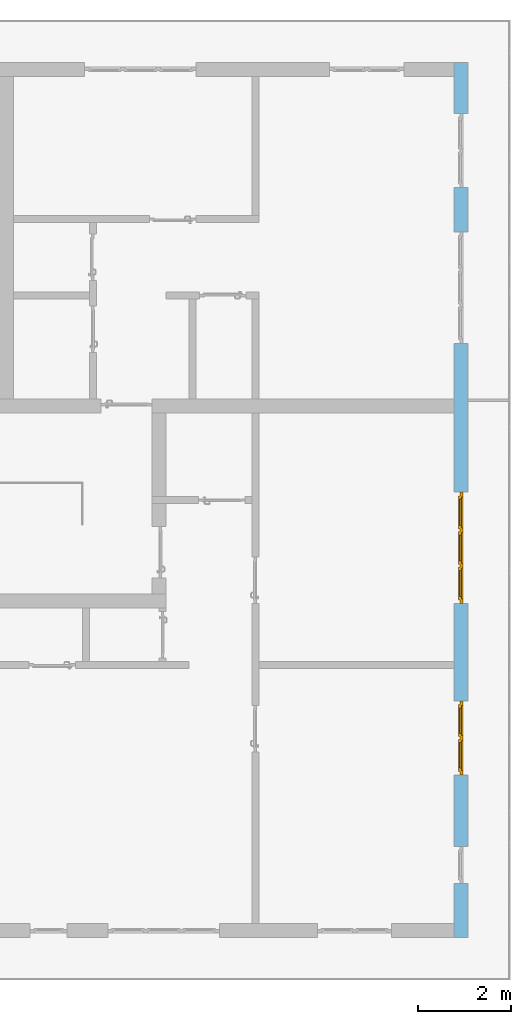
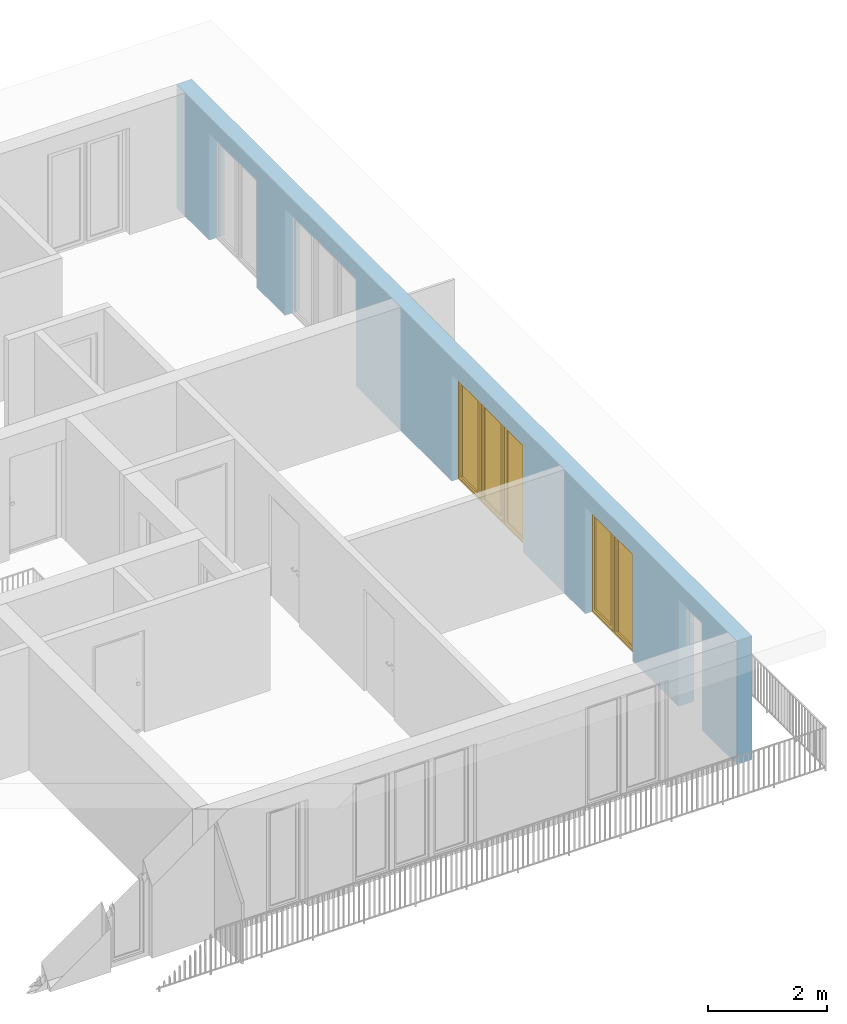
# One storey, part 22 of 54: 2 windows, 5 openings, plus 1 element that does not belong to this part.
"""IFC4 building model written with IfcOpenShell, lengths in metres."""

from ifc_helpers import new_model, entity, si_unit, converted_unit, derived_unit, direction, frame, origin_with_axes, place, context, subcontext, project, spatial, polygons, source, transform, mapped, material, type_object, element, fill, save


model = new_model("IFC4")

# Units and contexts
model_context = context("Model", 3, precision=1e-05, world=origin_with_axes(), true_north=direction((0.0, 1.0)))
body_context = subcontext(model_context, "Body", "Model", "MODEL_VIEW")
ifc_project = project(units=[si_unit("LENGTHUNIT", "METRE"), si_unit("AREAUNIT", "SQUARE_METRE"), si_unit("VOLUMEUNIT", "CUBIC_METRE"), converted_unit("PLANEANGLEUNIT", "DEGREE", entity("IfcPlaneAngleMeasure", 0.0174532925199), si_unit("PLANEANGLEUNIT", "RADIAN"), dimensions=[0, 0, 0, 0, 0, 0, 0]), converted_unit("TIMEUNIT", "Year", entity("IfcTimeMeasure", 31556926.0), si_unit("TIMEUNIT", "SECOND"), dimensions=[0, 0, 1, 0, 0, 0, 0]), si_unit("MASSUNIT", "GRAM", prefix="KILO"), si_unit("THERMODYNAMICTEMPERATUREUNIT", "DEGREE_CELSIUS"), si_unit("LUMINOUSINTENSITYUNIT", "LUMEN"), si_unit("ENERGYUNIT", "JOULE", prefix="MEGA"), derived_unit("THERMALCONDUCTANCEUNIT", [(si_unit("POWERUNIT", "WATT"), 1), (si_unit("LENGTHUNIT", "METRE"), -1), (si_unit("THERMODYNAMICTEMPERATUREUNIT", "KELVIN"), -1)]), derived_unit("SPECIFICHEATCAPACITYUNIT", [(si_unit("ENERGYUNIT", "JOULE"), 1), (si_unit("MASSUNIT", "GRAM", prefix="KILO"), -1), (si_unit("THERMODYNAMICTEMPERATUREUNIT", "KELVIN"), -1)]), derived_unit("MASSDENSITYUNIT", [(si_unit("MASSUNIT", "GRAM", prefix="KILO"), 1), (si_unit("VOLUMEUNIT", "CUBIC_METRE"), -1)])], contexts=[model_context])

# Site, building, storey
site_placement = place(None, origin_with_axes())
site = spatial("IfcSite", under=ifc_project, at=site_placement, CompositionType="ELEMENT")
building_placement = place(site_placement, origin_with_axes())
building = spatial("IfcBuilding", under=site, at=building_placement, CompositionType="ELEMENT")
storey_placement = place(building_placement, frame((0.0, 0.0, 9.18), z_axis=(0.0, 0.0, 1.0), x_axis=(1.0, 0.0, 0.0)))
storey = spatial("IfcBuildingStorey", under=building, at=storey_placement, Name="3. Geschoss", CompositionType="ELEMENT", Elevation=9.18)

# Wall, openings, windows
ifc_material = material()
wall_type = type_object("IfcWallType", Name="300", PredefinedType="NOTDEFINED")
wall_placement = place(storey_placement, frame((9.3378006196, -9.92881223104, 0.0), z_axis=(0.0, 0.0, 1.0), x_axis=(0.0, 1.0, 0.0)))
wall = element("IfcWall", 1, at=wall_placement, inside=storey, type_object=wall_type, material=ifc_material, Name="Wand-001", PredefinedType="NOTDEFINED", context=body_context, shape_type="Tessellation", body=[
    polygons([(1.16441876325, 0.1, 2.2), (1.96441876325, 0.1, 2.2), (1.96441876325, 0.0, 2.2), (1.16441876325, 0.0, 2.2), (1.16441876325, 0.3, 2.2), (1.96441876325, 0.3, 2.2), (1.96441876325, 0.1, 0.0), (1.96441876325, 0.0, 0.0), (18.85, 0.0, 2.54), (0.0, 0.0, 2.54), (0.0, 0.0, 0.0), (1.16441876325, 0.0, 0.0), (3.5, 0.0, 0.0), (3.5, 0.0, 2.2), (5.1, 0.0, 2.2), (5.1, 0.0, 0.0), (7.1921181063, 0.0, 0.0), (7.1921181063, 0.0, 2.2), (9.5921181063, 0.0, 2.2), (9.5921181063, 0.0, 0.0), (12.8, 0.0, 0.0), (12.8, 0.0, 2.2), (15.2, 0.0, 2.2), (15.2, 0.0, 0.0), (16.15, 0.0, 0.0), (16.15, 0.0, 2.2), (17.75, 0.0, 2.2), (17.75, 0.0, 0.0), (18.85, 0.0, 0.0), (1.16441876325, 0.1, 0.0), (1.16441876325, 0.3, 0.0), (0.0, 0.3, 0.0), (0.0, 0.3, 2.54), (18.85, 0.3, 2.54), (18.85, 0.3, 0.0), (17.75, 0.3, 0.0), (17.75, 0.3, 2.2), (16.15, 0.3, 2.2), (16.15, 0.3, 0.0), (15.2, 0.3, 0.0), (15.2, 0.3, 2.2), (12.8, 0.3, 2.2), (12.8, 0.3, 0.0), (9.5921181063, 0.3, 0.0), (9.5921181063, 0.3, 2.2), (7.1921181063, 0.3, 2.2), (7.1921181063, 0.3, 0.0), (5.1, 0.3, 0.0), (5.1, 0.3, 2.2), (3.5, 0.3, 2.2), (3.5, 0.3, 0.0), (1.96441876325, 0.3, 0.0), (3.5, 0.1, 0.0), (3.5, 0.1, 2.2), (5.1, 0.1, 2.2), (5.1, 0.1, 0.0), (7.1921181063, 0.1, 0.0), (7.1921181063, 0.1, 2.2), (9.5921181063, 0.1, 2.2), (9.5921181063, 0.1, 0.0), (12.8, 0.1, 0.0), (12.8, 0.1, 2.2), (15.2, 0.1, 2.2), (15.2, 0.1, 0.0), (16.15, 0.1, 0.0), (16.15, 0.1, 2.2), (17.75, 0.1, 2.2), (17.75, 0.1, 0.0)], [[[1, 2, 3, 4]], [[2, 1, 5, 6]], [[2, 7, 8, 3]], [[9, 10, 11, 12, 4, 3, 8, 13, 14, 15, 16, 17, 18, 19, 20, 21, 22, 23, 24, 25, 26, 27, 28, 29]], [[30, 1, 4, 12]], [[1, 30, 31, 5]], [[5, 31, 32, 33, 34, 35, 36, 37, 38, 39, 40, 41, 42, 43, 44, 45, 46, 47, 48, 49, 50, 51, 52, 6]], [[7, 2, 6, 52]], [[7, 52, 51, 53, 13, 8]], [[9, 34, 33, 10]], [[33, 32, 11, 10]], [[31, 30, 12, 11, 32]], [[14, 13, 53, 54]], [[15, 14, 54, 55]], [[16, 15, 55, 56]], [[56, 48, 47, 57, 17, 16]], [[57, 58, 18, 17]], [[58, 59, 19, 18]], [[59, 60, 20, 19]], [[60, 44, 43, 61, 21, 20]], [[22, 21, 61, 62]], [[23, 22, 62, 63]], [[24, 23, 63, 64]], [[64, 40, 39, 65, 25, 24]], [[65, 66, 26, 25]], [[66, 67, 27, 26]], [[67, 68, 28, 27]], [[36, 35, 29, 28, 68]], [[9, 29, 35, 34]], [[68, 67, 37, 36]], [[67, 66, 38, 37]], [[66, 65, 39, 38]], [[41, 40, 64, 63]], [[42, 41, 63, 62]], [[43, 42, 62, 61]], [[60, 59, 45, 44]], [[59, 58, 46, 45]], [[58, 57, 47, 46]], [[49, 48, 56, 55]], [[50, 49, 55, 54]], [[51, 50, 54, 53]]], closed=True),
])
opening_1_placement = place(wall_placement, frame((16.95, 0.0, 0.0), z_axis=(0.0, 0.0, 1.0), x_axis=(1.0, 0.0, 0.0)))
element("IfcOpeningElement", 2, at=opening_1_placement, cuts=wall, Name="Fenster-001", context=body_context, identifier="Reference", shape_type="Tessellation", body=[
    polygons([(0.8, 0.1, 0.0), (0.8, 0.1, 2.2), (0.8, -0.000999999999999, 2.2), (0.8, -0.000999999999999, 0.0), (0.8, 0.301, 0.0), (0.8, 0.301, 2.2), (-0.8, 0.1, 2.2), (-0.8, -0.000999999999999, 2.2), (-0.8, 0.301, 2.2), (-0.8, -0.000999999999999, 0.0), (-0.8, 0.1, 0.0), (-0.8, 0.301, 0.0)], [[[1, 2, 3, 4]], [[2, 1, 5, 6]], [[7, 8, 3, 2, 6, 9]], [[8, 10, 4, 3]], [[1, 4, 10, 11, 12, 5]], [[6, 5, 12, 9]], [[7, 11, 10, 8]], [[11, 7, 9, 12]]], closed=True),
])
opening_2_placement = place(wall_placement, frame((14.0, 0.0, 0.0), z_axis=(0.0, 0.0, 1.0), x_axis=(1.0, 0.0, 0.0)))
element("IfcOpeningElement", 3, at=opening_2_placement, cuts=wall, Name="Fenster-002", context=body_context, identifier="Reference", shape_type="Tessellation", body=[
    polygons([(1.2, 0.1, 0.0), (1.2, 0.1, 2.2), (1.2, -0.000999999999999, 2.2), (1.2, -0.000999999999999, 0.0), (1.2, 0.301, 0.0), (1.2, 0.301, 2.2), (-1.2, 0.1, 2.2), (-1.2, -0.000999999999999, 2.2), (-1.2, 0.301, 2.2), (-1.2, -0.000999999999999, 0.0), (-1.2, 0.1, 0.0), (-1.2, 0.301, 0.0)], [[[1, 2, 3, 4]], [[2, 1, 5, 6]], [[7, 8, 3, 2, 6, 9]], [[8, 10, 4, 3]], [[1, 4, 10, 11, 12, 5]], [[6, 5, 12, 9]], [[7, 11, 10, 8]], [[11, 7, 9, 12]]], closed=True),
])
opening_3_placement = place(wall_placement, frame((8.3921181063, 0.0, 0.0), z_axis=(0.0, 0.0, 1.0), x_axis=(1.0, 0.0, 0.0)))
opening_3 = element("IfcOpeningElement", 4, at=opening_3_placement, cuts=wall, Name="Fenster-002", context=body_context, identifier="Reference", shape_type="Tessellation", body=[
    polygons([(1.2, 0.1, 0.0), (1.2, 0.1, 2.2), (1.2, -0.000999999999999, 2.2), (1.2, -0.000999999999999, 0.0), (1.2, 0.301, 0.0), (1.2, 0.301, 2.2), (-1.2, 0.1, 2.2), (-1.2, -0.000999999999999, 2.2), (-1.2, 0.301, 2.2), (-1.2, -0.000999999999999, 0.0), (-1.2, 0.1, 0.0), (-1.2, 0.301, 0.0)], [[[1, 2, 3, 4]], [[2, 1, 5, 6]], [[7, 8, 3, 2, 6, 9]], [[8, 10, 4, 3]], [[1, 4, 10, 11, 12, 5]], [[6, 5, 12, 9]], [[7, 11, 10, 8]], [[11, 7, 9, 12]]], closed=True),
])
opening_4_placement = place(wall_placement, frame((4.3, 0.0, 0.0), z_axis=(0.0, 0.0, 1.0), x_axis=(1.0, 0.0, 0.0)))
opening_4 = element("IfcOpeningElement", 5, at=opening_4_placement, cuts=wall, Name="Fenster-001", context=body_context, identifier="Reference", shape_type="Tessellation", body=[
    polygons([(0.8, 0.1, 0.0), (0.8, 0.1, 2.2), (0.8, -0.000999999999999, 2.2), (0.8, -0.000999999999999, 0.0), (0.8, 0.301, 0.0), (0.8, 0.301, 2.2), (-0.8, 0.1, 2.2), (-0.8, -0.000999999999999, 2.2), (-0.8, 0.301, 2.2), (-0.8, -0.000999999999999, 0.0), (-0.8, 0.1, 0.0), (-0.8, 0.301, 0.0)], [[[1, 2, 3, 4]], [[2, 1, 5, 6]], [[7, 8, 3, 2, 6, 9]], [[8, 10, 4, 3]], [[1, 4, 10, 11, 12, 5]], [[6, 5, 12, 9]], [[7, 11, 10, 8]], [[11, 7, 9, 12]]], closed=True),
])
opening_5_placement = place(wall_placement, frame((1.56441876325, 0.0, 0.0), z_axis=(0.0, 0.0, 1.0), x_axis=(1.0, 0.0, 0.0)))
element("IfcOpeningElement", 6, at=opening_5_placement, cuts=wall, Name="Fenster-003", context=body_context, identifier="Reference", shape_type="Tessellation", body=[
    polygons([(0.4, 0.1, 0.0), (0.4, 0.1, 2.2), (0.4, -0.000999999999999, 2.2), (0.4, -0.000999999999999, 0.0), (0.4, 0.301, 0.0), (0.4, 0.301, 2.2), (-0.4, 0.1, 2.2), (-0.4, -0.000999999999999, 2.2), (-0.4, 0.301, 2.2), (-0.4, -0.000999999999999, 0.0), (-0.4, 0.1, 0.0), (-0.4, 0.301, 0.0)], [[[1, 2, 3, 4]], [[2, 1, 5, 6]], [[7, 8, 3, 2, 6, 9]], [[8, 10, 4, 3]], [[1, 4, 10, 11, 12, 5]], [[6, 5, 12, 9]], [[7, 11, 10, 8]], [[11, 7, 9, 12]]], closed=True),
])
window_type_1 = type_object("IfcWindowType", Name="3-1+1+1 26", PartitioningType="TRIPLE_PANEL_VERTICAL", PredefinedType="WINDOW")
shared_shape_1 = source(origin_with_axes(), body_context, "Body", "Tessellation", [
    polygons([(-1.2, -0.07, 0.0), (-1.2, 0.0, 0.0), (-1.1, 0.0, 0.1), (-1.1, -0.07, 0.1), (-1.2, -0.07, 2.2), (-1.2, 0.0, 2.2), (-1.1, 0.0, 2.1), (-1.1, -0.07, 2.1)], [[[1, 2, 3, 4]], [[5, 6, 2, 1]], [[2, 6, 7, 3]], [[4, 3, 7, 8]], [[1, 4, 8, 5]], [[8, 7, 6, 5]]], closed=True),
    polygons([(1.2, -0.07, 0.0), (1.2, 0.0, 0.0), (1.2, 0.0, 2.2), (1.2, -0.07, 2.2), (1.1, -0.07, 0.1), (1.1, 0.0, 0.1), (1.1, 0.0, 2.1), (1.1, -0.07, 2.1)], [[[1, 2, 3, 4]], [[5, 6, 2, 1]], [[2, 6, 7, 3]], [[4, 3, 7, 8]], [[1, 4, 8, 5]], [[8, 7, 6, 5]]], closed=True),
    polygons([(-1.2, -0.07, 0.0), (-1.2, 0.0, 0.0), (1.2, 0.0, 0.0), (1.2, -0.07, 0.0), (-1.1, -0.07, 0.1), (-1.1, 0.0, 0.1), (-0.433333333333, 0.0, 0.1), (-0.333333333333, 0.0, 0.1), (0.333333333333, 0.0, 0.1), (0.433333333333, 0.0, 0.1), (1.1, 0.0, 0.1), (1.1, -0.07, 0.1), (0.433333333333, -0.07, 0.1), (0.333333333333, -0.07, 0.1), (-0.333333333333, -0.07, 0.1), (-0.433333333333, -0.07, 0.1)], [[[1, 2, 3, 4]], [[5, 6, 2, 1]], [[2, 6, 7, 8, 9, 10, 11, 3]], [[4, 3, 11, 12]], [[1, 4, 12, 13, 14, 15, 16, 5]], [[16, 7, 6, 5]], [[15, 8, 7, 16]], [[14, 9, 8, 15]], [[13, 10, 9, 14]], [[12, 11, 10, 13]]], closed=True),
    polygons([(-1.2, -0.07, 2.2), (-1.2, 0.0, 2.2), (-1.1, 0.0, 2.1), (-1.1, -0.07, 2.1), (1.2, -0.07, 2.2), (1.2, 0.0, 2.2), (1.1, 0.0, 2.1), (0.433333333333, 0.0, 2.1), (0.333333333333, 0.0, 2.1), (-0.333333333333, 0.0, 2.1), (-0.433333333333, 0.0, 2.1), (-0.433333333333, -0.07, 2.1), (-0.333333333333, -0.07, 2.1), (0.333333333333, -0.07, 2.1), (0.433333333333, -0.07, 2.1), (1.1, -0.07, 2.1)], [[[1, 2, 3, 4]], [[5, 6, 2, 1]], [[2, 6, 7, 8, 9, 10, 11, 3]], [[4, 3, 11, 12]], [[1, 4, 12, 13, 14, 15, 16, 5]], [[16, 7, 6, 5]], [[15, 8, 7, 16]], [[14, 9, 8, 15]], [[13, 10, 9, 14]], [[12, 11, 10, 13]]], closed=True),
    polygons([(0.333333333333, -0.07, 0.1), (0.333333333333, 0.0, 0.1), (0.433333333333, 0.0, 0.1), (0.433333333333, -0.07, 0.1), (0.333333333333, -0.07, 2.1), (0.333333333333, 0.0, 2.1), (0.433333333333, 0.0, 2.1), (0.433333333333, -0.07, 2.1)], [[[1, 2, 3, 4]], [[5, 6, 2, 1]], [[2, 6, 7, 3]], [[4, 3, 7, 8]], [[1, 4, 8, 5]], [[8, 7, 6, 5]]], closed=True),
    polygons([(-0.433333333333, -0.07, 0.1), (-0.433333333333, 0.0, 0.1), (-0.333333333333, 0.0, 0.1), (-0.333333333333, -0.07, 0.1), (-0.433333333333, -0.07, 2.1), (-0.433333333333, 0.0, 2.1), (-0.333333333333, 0.0, 2.1), (-0.333333333333, -0.07, 2.1)], [[[1, 2, 3, 4]], [[5, 6, 2, 1]], [[2, 6, 7, 3]], [[4, 3, 7, 8]], [[1, 4, 8, 5]], [[8, 7, 6, 5]]], closed=True),
    polygons([(-1.12, 0.0, 0.08), (-1.12, 0.03, 0.08), (-1.05, 0.03, 0.15), (-1.05, 0.0, 0.15), (-1.12, 0.0, 2.12), (-1.12, 0.03, 2.12), (-1.05, 0.03, 2.05), (-1.05, 0.0, 2.05)], [[[1, 2, 3, 4]], [[5, 6, 2, 1]], [[2, 6, 7, 3]], [[4, 3, 7, 8]], [[1, 4, 8, 5]], [[8, 7, 6, 5]]], closed=True),
    polygons([(-0.413333333333, 0.0, 0.08), (-0.483333333333, 0.0, 0.15), (-0.483333333333, 0.03, 0.15), (-0.413333333333, 0.03, 0.08), (-0.413333333333, 0.0, 2.12), (-0.483333333333, 0.0, 2.05), (-0.483333333333, 0.03, 2.05), (-0.413333333333, 0.03, 2.12)], [[[1, 2, 3, 4]], [[1, 5, 6, 2]], [[2, 6, 7, 3]], [[4, 3, 7, 8]], [[5, 1, 4, 8]], [[6, 5, 8, 7]]], closed=True),
    polygons([(-1.12, 0.0, 0.08), (-1.12, 0.03, 0.08), (-0.413333333333, 0.03, 0.08), (-0.413333333333, 0.0, 0.08), (-1.05, 0.0, 0.15), (-1.05, 0.03, 0.15), (-0.483333333333, 0.03, 0.15), (-0.483333333333, 0.0, 0.15)], [[[1, 2, 3, 4]], [[5, 6, 2, 1]], [[2, 6, 7, 3]], [[4, 3, 7, 8]], [[1, 4, 8, 5]], [[8, 7, 6, 5]]], closed=True),
    polygons([(-1.12, 0.0, 2.12), (-0.413333333333, 0.0, 2.12), (-0.413333333333, 0.03, 2.12), (-1.12, 0.03, 2.12), (-1.05, 0.0, 2.05), (-0.483333333333, 0.0, 2.05), (-0.483333333333, 0.03, 2.05), (-1.05, 0.03, 2.05)], [[[1, 2, 3, 4]], [[1, 5, 6, 2]], [[2, 6, 7, 3]], [[4, 3, 7, 8]], [[5, 1, 4, 8]], [[6, 5, 8, 7]]], closed=True),
    polygons([(-1.1, -0.03, 0.1), (-1.1, 0.0, 0.1), (-1.05, 0.0, 0.15), (-1.05, -0.03, 0.15), (-1.1, -0.03, 2.1), (-1.1, 0.0, 2.1), (-1.05, 0.0, 2.05), (-1.05, -0.03, 2.05)], [[[1, 2, 3, 4]], [[5, 6, 2, 1]], [[2, 6, 7, 3]], [[4, 3, 7, 8]], [[1, 4, 8, 5]], [[8, 7, 6, 5]]], closed=True),
    polygons([(-0.433333333333, -0.03, 0.1), (-0.483333333333, -0.03, 0.15), (-0.483333333333, 0.0, 0.15), (-0.433333333333, 0.0, 0.1), (-0.433333333333, -0.03, 2.1), (-0.483333333333, -0.03, 2.05), (-0.483333333333, 0.0, 2.05), (-0.433333333333, 0.0, 2.1)], [[[1, 2, 3, 4]], [[1, 5, 6, 2]], [[2, 6, 7, 3]], [[4, 3, 7, 8]], [[5, 1, 4, 8]], [[6, 5, 8, 7]]], closed=True),
    polygons([(-1.1, -0.03, 0.1), (-1.1, 0.0, 0.1), (-0.433333333333, 0.0, 0.1), (-0.433333333333, -0.03, 0.1), (-1.05, -0.03, 0.15), (-1.05, 0.0, 0.15), (-0.483333333333, 0.0, 0.15), (-0.483333333333, -0.03, 0.15)], [[[1, 2, 3, 4]], [[5, 6, 2, 1]], [[2, 6, 7, 3]], [[4, 3, 7, 8]], [[1, 4, 8, 5]], [[8, 7, 6, 5]]], closed=True),
    polygons([(-1.1, -0.03, 2.1), (-0.433333333333, -0.03, 2.1), (-0.433333333333, 0.0, 2.1), (-1.1, 0.0, 2.1), (-1.05, -0.03, 2.05), (-0.483333333333, -0.03, 2.05), (-0.483333333333, 0.0, 2.05), (-1.05, 0.0, 2.05)], [[[1, 2, 3, 4]], [[1, 5, 6, 2]], [[2, 6, 7, 3]], [[4, 3, 7, 8]], [[5, 1, 4, 8]], [[6, 5, 8, 7]]], closed=True),
    polygons([(-1.05, -0.005, 0.15), (-1.05, 0.005, 0.15), (-0.483333333333, 0.005, 0.15), (-0.483333333333, -0.005, 0.15), (-1.05, -0.005, 2.05), (-1.05, 0.005, 2.05), (-0.483333333333, 0.005, 2.05), (-0.483333333333, -0.005, 2.05)], [[[1, 2, 3, 4]], [[5, 6, 2, 1]], [[2, 6, 7, 3]], [[4, 3, 7, 8]], [[1, 4, 8, 5]], [[8, 7, 6, 5]]], closed=True),
    polygons([(-0.353333333333, 0.0, 0.08), (-0.353333333333, 0.03, 0.08), (-0.283333333333, 0.03, 0.15), (-0.283333333333, 0.0, 0.15), (-0.353333333333, 0.0, 2.12), (-0.353333333333, 0.03, 2.12), (-0.283333333333, 0.03, 2.05), (-0.283333333333, 0.0, 2.05)], [[[1, 2, 3, 4]], [[5, 6, 2, 1]], [[2, 6, 7, 3]], [[4, 3, 7, 8]], [[1, 4, 8, 5]], [[8, 7, 6, 5]]], closed=True),
    polygons([(0.353333333333, 0.0, 0.08), (0.283333333333, 0.0, 0.15), (0.283333333333, 0.03, 0.15), (0.353333333333, 0.03, 0.08), (0.353333333333, 0.0, 2.12), (0.283333333333, 0.0, 2.05), (0.283333333333, 0.03, 2.05), (0.353333333333, 0.03, 2.12)], [[[1, 2, 3, 4]], [[1, 5, 6, 2]], [[2, 6, 7, 3]], [[4, 3, 7, 8]], [[5, 1, 4, 8]], [[6, 5, 8, 7]]], closed=True),
    polygons([(-0.353333333333, 0.0, 0.08), (-0.353333333333, 0.03, 0.08), (0.353333333333, 0.03, 0.08), (0.353333333333, 0.0, 0.08), (-0.283333333333, 0.0, 0.15), (-0.283333333333, 0.03, 0.15), (0.283333333333, 0.03, 0.15), (0.283333333333, 0.0, 0.15)], [[[1, 2, 3, 4]], [[5, 6, 2, 1]], [[2, 6, 7, 3]], [[4, 3, 7, 8]], [[1, 4, 8, 5]], [[8, 7, 6, 5]]], closed=True),
    polygons([(-0.353333333333, 0.0, 2.12), (0.353333333333, 0.0, 2.12), (0.353333333333, 0.03, 2.12), (-0.353333333333, 0.03, 2.12), (-0.283333333333, 0.0, 2.05), (0.283333333333, 0.0, 2.05), (0.283333333333, 0.03, 2.05), (-0.283333333333, 0.03, 2.05)], [[[1, 2, 3, 4]], [[1, 5, 6, 2]], [[2, 6, 7, 3]], [[4, 3, 7, 8]], [[5, 1, 4, 8]], [[6, 5, 8, 7]]], closed=True),
    polygons([(-0.333333333333, -0.03, 0.1), (-0.333333333333, 0.0, 0.1), (-0.283333333333, 0.0, 0.15), (-0.283333333333, -0.03, 0.15), (-0.333333333333, -0.03, 2.1), (-0.333333333333, 0.0, 2.1), (-0.283333333333, 0.0, 2.05), (-0.283333333333, -0.03, 2.05)], [[[1, 2, 3, 4]], [[5, 6, 2, 1]], [[2, 6, 7, 3]], [[4, 3, 7, 8]], [[1, 4, 8, 5]], [[8, 7, 6, 5]]], closed=True),
    polygons([(0.333333333333, -0.03, 0.1), (0.283333333333, -0.03, 0.15), (0.283333333333, 0.0, 0.15), (0.333333333333, 0.0, 0.1), (0.333333333333, -0.03, 2.1), (0.283333333333, -0.03, 2.05), (0.283333333333, 0.0, 2.05), (0.333333333333, 0.0, 2.1)], [[[1, 2, 3, 4]], [[1, 5, 6, 2]], [[2, 6, 7, 3]], [[4, 3, 7, 8]], [[5, 1, 4, 8]], [[6, 5, 8, 7]]], closed=True),
    polygons([(-0.333333333333, -0.03, 0.1), (-0.333333333333, 0.0, 0.1), (0.333333333333, 0.0, 0.1), (0.333333333333, -0.03, 0.1), (-0.283333333333, -0.03, 0.15), (-0.283333333333, 0.0, 0.15), (0.283333333333, 0.0, 0.15), (0.283333333333, -0.03, 0.15)], [[[1, 2, 3, 4]], [[5, 6, 2, 1]], [[2, 6, 7, 3]], [[4, 3, 7, 8]], [[1, 4, 8, 5]], [[8, 7, 6, 5]]], closed=True),
    polygons([(-0.333333333333, -0.03, 2.1), (0.333333333333, -0.03, 2.1), (0.333333333333, 0.0, 2.1), (-0.333333333333, 0.0, 2.1), (-0.283333333333, -0.03, 2.05), (0.283333333333, -0.03, 2.05), (0.283333333333, 0.0, 2.05), (-0.283333333333, 0.0, 2.05)], [[[1, 2, 3, 4]], [[1, 5, 6, 2]], [[2, 6, 7, 3]], [[4, 3, 7, 8]], [[5, 1, 4, 8]], [[6, 5, 8, 7]]], closed=True),
    polygons([(-0.283333333333, -0.005, 0.15), (-0.283333333333, 0.005, 0.15), (0.283333333333, 0.005, 0.15), (0.283333333333, -0.005, 0.15), (-0.283333333333, -0.005, 2.05), (-0.283333333333, 0.005, 2.05), (0.283333333333, 0.005, 2.05), (0.283333333333, -0.005, 2.05)], [[[1, 2, 3, 4]], [[5, 6, 2, 1]], [[2, 6, 7, 3]], [[4, 3, 7, 8]], [[1, 4, 8, 5]], [[8, 7, 6, 5]]], closed=True),
    polygons([(0.413333333333, 0.0, 0.08), (0.413333333333, 0.03, 0.08), (0.483333333333, 0.03, 0.15), (0.483333333333, 0.0, 0.15), (0.413333333333, 0.0, 2.12), (0.413333333333, 0.03, 2.12), (0.483333333333, 0.03, 2.05), (0.483333333333, 0.0, 2.05)], [[[1, 2, 3, 4]], [[5, 6, 2, 1]], [[2, 6, 7, 3]], [[4, 3, 7, 8]], [[1, 4, 8, 5]], [[8, 7, 6, 5]]], closed=True),
    polygons([(1.12, 0.0, 0.08), (1.05, 0.0, 0.15), (1.05, 0.03, 0.15), (1.12, 0.03, 0.08), (1.12, 0.0, 2.12), (1.05, 0.0, 2.05), (1.05, 0.03, 2.05), (1.12, 0.03, 2.12)], [[[1, 2, 3, 4]], [[1, 5, 6, 2]], [[2, 6, 7, 3]], [[4, 3, 7, 8]], [[5, 1, 4, 8]], [[6, 5, 8, 7]]], closed=True),
    polygons([(0.413333333333, 0.0, 0.08), (0.413333333333, 0.03, 0.08), (1.12, 0.03, 0.08), (1.12, 0.0, 0.08), (0.483333333333, 0.0, 0.15), (0.483333333333, 0.03, 0.15), (1.05, 0.03, 0.15), (1.05, 0.0, 0.15)], [[[1, 2, 3, 4]], [[5, 6, 2, 1]], [[2, 6, 7, 3]], [[4, 3, 7, 8]], [[1, 4, 8, 5]], [[8, 7, 6, 5]]], closed=True),
    polygons([(0.413333333333, 0.0, 2.12), (1.12, 0.0, 2.12), (1.12, 0.03, 2.12), (0.413333333333, 0.03, 2.12), (0.483333333333, 0.0, 2.05), (1.05, 0.0, 2.05), (1.05, 0.03, 2.05), (0.483333333333, 0.03, 2.05)], [[[1, 2, 3, 4]], [[1, 5, 6, 2]], [[2, 6, 7, 3]], [[4, 3, 7, 8]], [[5, 1, 4, 8]], [[6, 5, 8, 7]]], closed=True),
    polygons([(0.433333333333, -0.03, 0.1), (0.433333333333, 0.0, 0.1), (0.483333333333, 0.0, 0.15), (0.483333333333, -0.03, 0.15), (0.433333333333, -0.03, 2.1), (0.433333333333, 0.0, 2.1), (0.483333333333, 0.0, 2.05), (0.483333333333, -0.03, 2.05)], [[[1, 2, 3, 4]], [[5, 6, 2, 1]], [[2, 6, 7, 3]], [[4, 3, 7, 8]], [[1, 4, 8, 5]], [[8, 7, 6, 5]]], closed=True),
    polygons([(1.1, -0.03, 0.1), (1.05, -0.03, 0.15), (1.05, 0.0, 0.15), (1.1, 0.0, 0.1), (1.1, -0.03, 2.1), (1.05, -0.03, 2.05), (1.05, 0.0, 2.05), (1.1, 0.0, 2.1)], [[[1, 2, 3, 4]], [[1, 5, 6, 2]], [[2, 6, 7, 3]], [[4, 3, 7, 8]], [[5, 1, 4, 8]], [[6, 5, 8, 7]]], closed=True),
    polygons([(0.433333333333, -0.03, 0.1), (0.433333333333, 0.0, 0.1), (1.1, 0.0, 0.1), (1.1, -0.03, 0.1), (0.483333333333, -0.03, 0.15), (0.483333333333, 0.0, 0.15), (1.05, 0.0, 0.15), (1.05, -0.03, 0.15)], [[[1, 2, 3, 4]], [[5, 6, 2, 1]], [[2, 6, 7, 3]], [[4, 3, 7, 8]], [[1, 4, 8, 5]], [[8, 7, 6, 5]]], closed=True),
    polygons([(0.433333333333, -0.03, 2.1), (1.1, -0.03, 2.1), (1.1, 0.0, 2.1), (0.433333333333, 0.0, 2.1), (0.483333333333, -0.03, 2.05), (1.05, -0.03, 2.05), (1.05, 0.0, 2.05), (0.483333333333, 0.0, 2.05)], [[[1, 2, 3, 4]], [[1, 5, 6, 2]], [[2, 6, 7, 3]], [[4, 3, 7, 8]], [[5, 1, 4, 8]], [[6, 5, 8, 7]]], closed=True),
    polygons([(0.483333333333, -0.005, 0.15), (0.483333333333, 0.005, 0.15), (1.05, 0.005, 0.15), (1.05, -0.005, 0.15), (0.483333333333, -0.005, 2.05), (0.483333333333, 0.005, 2.05), (1.05, 0.005, 2.05), (1.05, -0.005, 2.05)], [[[1, 2, 3, 4]], [[5, 6, 2, 1]], [[2, 6, 7, 3]], [[4, 3, 7, 8]], [[1, 4, 8, 5]], [[8, 7, 6, 5]]], closed=True),
])
window_1_placement = place(opening_3_placement, frame((-1.2, 0.0, 0.0), z_axis=(0.0, 0.0, 1.0), x_axis=(1.0, 0.0, 0.0)))
window_1 = element("IfcWindow", 7, at=window_1_placement, inside=storey, type_object=window_type_1, Name="Fenster-002", OverallHeight=2.2, OverallWidth=2.4, PredefinedType="WINDOW", context=body_context, shape_type="MappedRepresentation", body=[
    mapped(shared_shape_1, transform((1.2, 0.17, 0.0))),
])
fill(opening_3, window_1)
window_type_2 = type_object("IfcWindowType", Name="2-1+1 26", PartitioningType="DOUBLE_PANEL_VERTICAL", PredefinedType="WINDOW")
shared_shape_2 = source(origin_with_axes(), body_context, "Body", "Tessellation", [
    polygons([(0.8, -0.07, 0.0), (0.7, -0.07, 0.1), (0.7, 0.0, 0.1), (0.8, 0.0, 0.0), (0.8, -0.07, 2.2), (0.7, -0.07, 2.1), (0.7, 0.0, 2.1), (0.8, 0.0, 2.2)], [[[1, 2, 3, 4]], [[1, 5, 6, 2]], [[2, 6, 7, 3]], [[4, 3, 7, 8]], [[5, 1, 4, 8]], [[6, 5, 8, 7]]], closed=True),
    polygons([(-0.8, -0.07, 0.0), (-0.8, -0.07, 2.2), (-0.8, 0.0, 2.2), (-0.8, 0.0, 0.0), (-0.7, -0.07, 0.1), (-0.7, -0.07, 2.1), (-0.7, 0.0, 2.1), (-0.7, 0.0, 0.1)], [[[1, 2, 3, 4]], [[1, 5, 6, 2]], [[2, 6, 7, 3]], [[4, 3, 7, 8]], [[5, 1, 4, 8]], [[6, 5, 8, 7]]], closed=True),
    polygons([(0.8, -0.07, 0.0), (-0.8, -0.07, 0.0), (-0.8, 0.0, 0.0), (0.8, 0.0, 0.0), (0.7, -0.07, 0.1), (0.05, -0.07, 0.1), (-0.05, -0.07, 0.1), (-0.7, -0.07, 0.1), (-0.7, 0.0, 0.1), (-0.05, 0.0, 0.1), (0.05, 0.0, 0.1), (0.7, 0.0, 0.1)], [[[1, 2, 3, 4]], [[1, 5, 6, 7, 8, 2]], [[2, 8, 9, 3]], [[4, 3, 9, 10, 11, 12]], [[5, 1, 4, 12]], [[6, 5, 12, 11]], [[7, 6, 11, 10]], [[8, 7, 10, 9]]], closed=True),
    polygons([(0.8, -0.07, 2.2), (0.7, -0.07, 2.1), (0.7, 0.0, 2.1), (0.8, 0.0, 2.2), (-0.8, -0.07, 2.2), (-0.7, -0.07, 2.1), (-0.05, -0.07, 2.1), (0.05, -0.07, 2.1), (0.05, 0.0, 2.1), (-0.05, 0.0, 2.1), (-0.7, 0.0, 2.1), (-0.8, 0.0, 2.2)], [[[1, 2, 3, 4]], [[1, 5, 6, 7, 8, 2]], [[2, 8, 9, 3]], [[4, 3, 9, 10, 11, 12]], [[5, 1, 4, 12]], [[6, 5, 12, 11]], [[7, 6, 11, 10]], [[8, 7, 10, 9]]], closed=True),
    polygons([(0.05, -0.07, 0.1), (-0.05, -0.07, 0.1), (-0.05, 0.0, 0.1), (0.05, 0.0, 0.1), (0.05, -0.07, 2.1), (-0.05, -0.07, 2.1), (-0.05, 0.0, 2.1), (0.05, 0.0, 2.1)], [[[1, 2, 3, 4]], [[1, 5, 6, 2]], [[2, 6, 7, 3]], [[4, 3, 7, 8]], [[5, 1, 4, 8]], [[6, 5, 8, 7]]], closed=True),
    polygons([(0.72, 0.0, 0.08), (0.65, 0.0, 0.15), (0.65, 0.03, 0.15), (0.72, 0.03, 0.08), (0.72, 0.0, 2.12), (0.65, 0.0, 2.05), (0.65, 0.03, 2.05), (0.72, 0.03, 2.12)], [[[1, 2, 3, 4]], [[1, 5, 6, 2]], [[2, 6, 7, 3]], [[4, 3, 7, 8]], [[5, 1, 4, 8]], [[6, 5, 8, 7]]], closed=True),
    polygons([(0.03, 0.0, 0.08), (0.03, 0.03, 0.08), (0.1, 0.03, 0.15), (0.1, 0.0, 0.15), (0.03, 0.0, 2.12), (0.03, 0.03, 2.12), (0.1, 0.03, 2.05), (0.1, 0.0, 2.05)], [[[1, 2, 3, 4]], [[5, 6, 2, 1]], [[2, 6, 7, 3]], [[4, 3, 7, 8]], [[1, 4, 8, 5]], [[8, 7, 6, 5]]], closed=True),
    polygons([(0.72, 0.0, 0.08), (0.03, 0.0, 0.08), (0.03, 0.03, 0.08), (0.72, 0.03, 0.08), (0.65, 0.0, 0.15), (0.1, 0.0, 0.15), (0.1, 0.03, 0.15), (0.65, 0.03, 0.15)], [[[1, 2, 3, 4]], [[1, 5, 6, 2]], [[2, 6, 7, 3]], [[4, 3, 7, 8]], [[5, 1, 4, 8]], [[6, 5, 8, 7]]], closed=True),
    polygons([(0.72, 0.0, 2.12), (0.72, 0.03, 2.12), (0.03, 0.03, 2.12), (0.03, 0.0, 2.12), (0.65, 0.0, 2.05), (0.65, 0.03, 2.05), (0.1, 0.03, 2.05), (0.1, 0.0, 2.05)], [[[1, 2, 3, 4]], [[5, 6, 2, 1]], [[2, 6, 7, 3]], [[4, 3, 7, 8]], [[1, 4, 8, 5]], [[8, 7, 6, 5]]], closed=True),
    polygons([(0.7, -0.03, 0.1), (0.65, -0.03, 0.15), (0.65, 0.0, 0.15), (0.7, 0.0, 0.1), (0.7, -0.03, 2.1), (0.65, -0.03, 2.05), (0.65, 0.0, 2.05), (0.7, 0.0, 2.1)], [[[1, 2, 3, 4]], [[1, 5, 6, 2]], [[2, 6, 7, 3]], [[4, 3, 7, 8]], [[5, 1, 4, 8]], [[6, 5, 8, 7]]], closed=True),
    polygons([(0.05, -0.03, 0.1), (0.05, 0.0, 0.1), (0.1, 0.0, 0.15), (0.1, -0.03, 0.15), (0.05, -0.03, 2.1), (0.05, 0.0, 2.1), (0.1, 0.0, 2.05), (0.1, -0.03, 2.05)], [[[1, 2, 3, 4]], [[5, 6, 2, 1]], [[2, 6, 7, 3]], [[4, 3, 7, 8]], [[1, 4, 8, 5]], [[8, 7, 6, 5]]], closed=True),
    polygons([(0.7, -0.03, 0.1), (0.05, -0.03, 0.1), (0.05, 0.0, 0.1), (0.7, 0.0, 0.1), (0.65, -0.03, 0.15), (0.1, -0.03, 0.15), (0.1, 0.0, 0.15), (0.65, 0.0, 0.15)], [[[1, 2, 3, 4]], [[1, 5, 6, 2]], [[2, 6, 7, 3]], [[4, 3, 7, 8]], [[5, 1, 4, 8]], [[6, 5, 8, 7]]], closed=True),
    polygons([(0.7, -0.03, 2.1), (0.7, 0.0, 2.1), (0.05, 0.0, 2.1), (0.05, -0.03, 2.1), (0.65, -0.03, 2.05), (0.65, 0.0, 2.05), (0.1, 0.0, 2.05), (0.1, -0.03, 2.05)], [[[1, 2, 3, 4]], [[5, 6, 2, 1]], [[2, 6, 7, 3]], [[4, 3, 7, 8]], [[1, 4, 8, 5]], [[8, 7, 6, 5]]], closed=True),
    polygons([(0.65, -0.005, 0.15), (0.1, -0.005, 0.15), (0.1, 0.005, 0.15), (0.65, 0.005, 0.15), (0.65, -0.005, 2.05), (0.1, -0.005, 2.05), (0.1, 0.005, 2.05), (0.65, 0.005, 2.05)], [[[1, 2, 3, 4]], [[1, 5, 6, 2]], [[2, 6, 7, 3]], [[4, 3, 7, 8]], [[5, 1, 4, 8]], [[6, 5, 8, 7]]], closed=True),
    polygons([(-0.03, 0.0, 0.08), (-0.1, 0.0, 0.15), (-0.1, 0.03, 0.15), (-0.03, 0.03, 0.08), (-0.03, 0.0, 2.12), (-0.1, 0.0, 2.05), (-0.1, 0.03, 2.05), (-0.03, 0.03, 2.12)], [[[1, 2, 3, 4]], [[1, 5, 6, 2]], [[2, 6, 7, 3]], [[4, 3, 7, 8]], [[5, 1, 4, 8]], [[6, 5, 8, 7]]], closed=True),
    polygons([(-0.72, 0.0, 0.08), (-0.72, 0.03, 0.08), (-0.65, 0.03, 0.15), (-0.65, 0.0, 0.15), (-0.72, 0.0, 2.12), (-0.72, 0.03, 2.12), (-0.65, 0.03, 2.05), (-0.65, 0.0, 2.05)], [[[1, 2, 3, 4]], [[5, 6, 2, 1]], [[2, 6, 7, 3]], [[4, 3, 7, 8]], [[1, 4, 8, 5]], [[8, 7, 6, 5]]], closed=True),
    polygons([(-0.03, 0.0, 0.08), (-0.72, 0.0, 0.08), (-0.72, 0.03, 0.08), (-0.03, 0.03, 0.08), (-0.1, 0.0, 0.15), (-0.65, 0.0, 0.15), (-0.65, 0.03, 0.15), (-0.1, 0.03, 0.15)], [[[1, 2, 3, 4]], [[1, 5, 6, 2]], [[2, 6, 7, 3]], [[4, 3, 7, 8]], [[5, 1, 4, 8]], [[6, 5, 8, 7]]], closed=True),
    polygons([(-0.03, 0.0, 2.12), (-0.03, 0.03, 2.12), (-0.72, 0.03, 2.12), (-0.72, 0.0, 2.12), (-0.1, 0.0, 2.05), (-0.1, 0.03, 2.05), (-0.65, 0.03, 2.05), (-0.65, 0.0, 2.05)], [[[1, 2, 3, 4]], [[5, 6, 2, 1]], [[2, 6, 7, 3]], [[4, 3, 7, 8]], [[1, 4, 8, 5]], [[8, 7, 6, 5]]], closed=True),
    polygons([(-0.05, -0.03, 0.1), (-0.1, -0.03, 0.15), (-0.1, 0.0, 0.15), (-0.05, 0.0, 0.1), (-0.05, -0.03, 2.1), (-0.1, -0.03, 2.05), (-0.1, 0.0, 2.05), (-0.05, 0.0, 2.1)], [[[1, 2, 3, 4]], [[1, 5, 6, 2]], [[2, 6, 7, 3]], [[4, 3, 7, 8]], [[5, 1, 4, 8]], [[6, 5, 8, 7]]], closed=True),
    polygons([(-0.7, -0.03, 0.1), (-0.7, 0.0, 0.1), (-0.65, 0.0, 0.15), (-0.65, -0.03, 0.15), (-0.7, -0.03, 2.1), (-0.7, 0.0, 2.1), (-0.65, 0.0, 2.05), (-0.65, -0.03, 2.05)], [[[1, 2, 3, 4]], [[5, 6, 2, 1]], [[2, 6, 7, 3]], [[4, 3, 7, 8]], [[1, 4, 8, 5]], [[8, 7, 6, 5]]], closed=True),
    polygons([(-0.05, -0.03, 0.1), (-0.7, -0.03, 0.1), (-0.7, 0.0, 0.1), (-0.05, 0.0, 0.1), (-0.1, -0.03, 0.15), (-0.65, -0.03, 0.15), (-0.65, 0.0, 0.15), (-0.1, 0.0, 0.15)], [[[1, 2, 3, 4]], [[1, 5, 6, 2]], [[2, 6, 7, 3]], [[4, 3, 7, 8]], [[5, 1, 4, 8]], [[6, 5, 8, 7]]], closed=True),
    polygons([(-0.05, -0.03, 2.1), (-0.05, 0.0, 2.1), (-0.7, 0.0, 2.1), (-0.7, -0.03, 2.1), (-0.1, -0.03, 2.05), (-0.1, 0.0, 2.05), (-0.65, 0.0, 2.05), (-0.65, -0.03, 2.05)], [[[1, 2, 3, 4]], [[5, 6, 2, 1]], [[2, 6, 7, 3]], [[4, 3, 7, 8]], [[1, 4, 8, 5]], [[8, 7, 6, 5]]], closed=True),
    polygons([(-0.1, -0.005, 0.15), (-0.65, -0.005, 0.15), (-0.65, 0.005, 0.15), (-0.1, 0.005, 0.15), (-0.1, -0.005, 2.05), (-0.65, -0.005, 2.05), (-0.65, 0.005, 2.05), (-0.1, 0.005, 2.05)], [[[1, 2, 3, 4]], [[1, 5, 6, 2]], [[2, 6, 7, 3]], [[4, 3, 7, 8]], [[5, 1, 4, 8]], [[6, 5, 8, 7]]], closed=True),
])
window_2_placement = place(opening_4_placement, frame((-0.8, 0.0, 0.0), z_axis=(0.0, 0.0, 1.0), x_axis=(1.0, 0.0, 0.0)))
window_2 = element("IfcWindow", 8, at=window_2_placement, inside=storey, type_object=window_type_2, Name="Fenster-001", OverallHeight=2.2, OverallWidth=1.6, PredefinedType="WINDOW", context=body_context, shape_type="MappedRepresentation", body=[
    mapped(shared_shape_2, transform((0.8, 0.17, 0.0))),
])
fill(opening_4, window_2)

save(model, "model.ifc")
